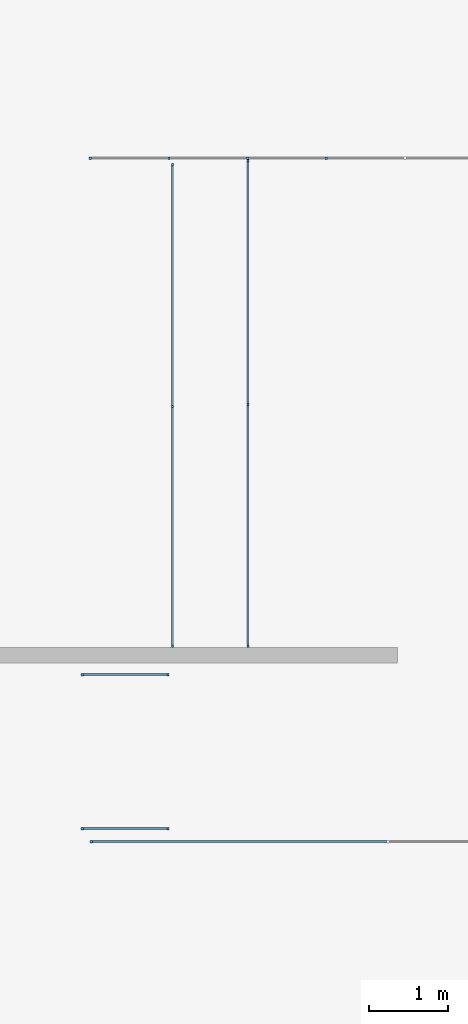
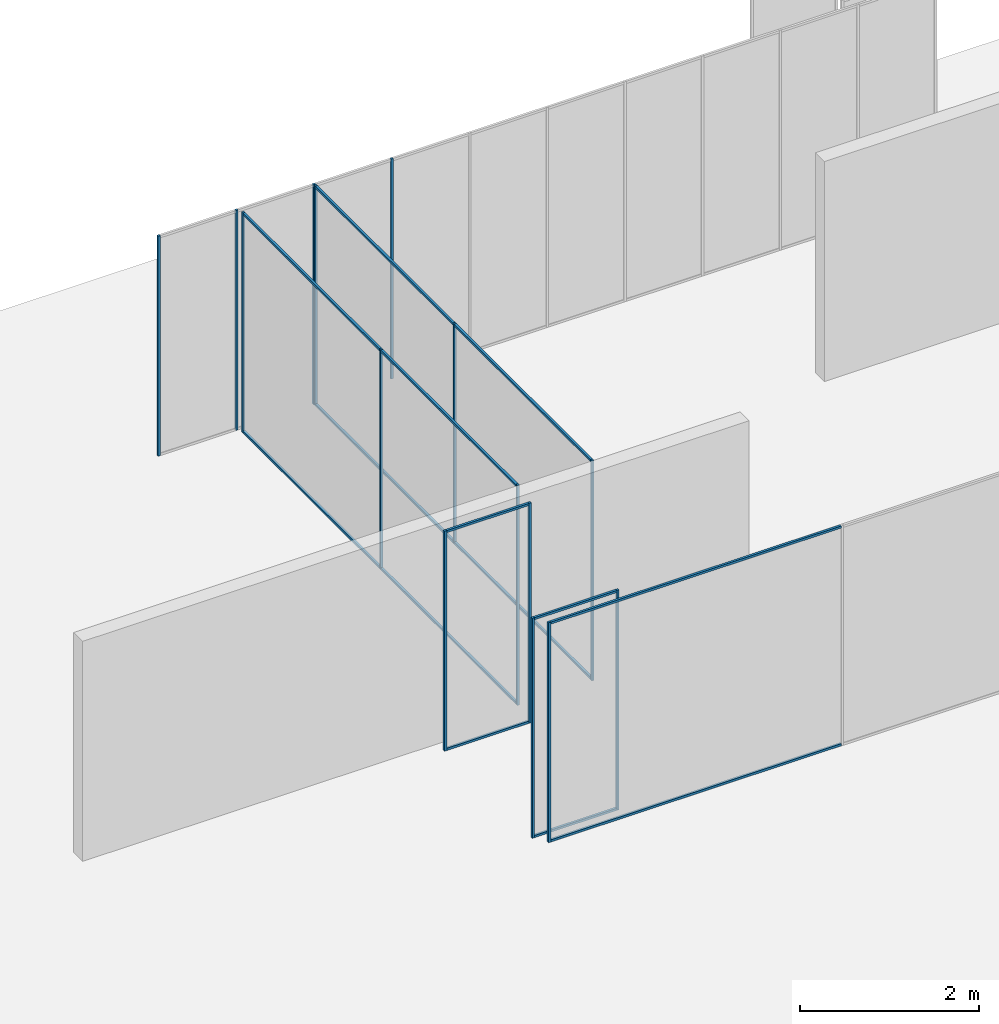
# One storey, part 1 of 8: 29 members, 6 elements without a shape of their own.
"""IFC2X3 building model written with IfcOpenShell, lengths in millimetres."""

import ifcopenshell
import ifcopenshell.guid

model = None  # the IFC model being written
_history = None  # IfcOwnerHistory: only IFC2X3 demands one
_inside = {}  # id of a spatial element -> (the spatial element, [elements in it])
_under = {}  # id of a project, library or spatial element -> (it, [spatial elements below it])
_declared = {}  # id of a project -> (the project, [libraries it declares])
_typed = {}  # id of a type object -> (the type object, [elements of that type])
_made_of = {}  # id of a material, layer set ... -> (it, [elements and type objects made of it])


def new_model(schema):
    """Start an empty IFC model of exactly this schema.

    Asked for "IFC4X3", IfcOpenShell would pick the latest addendum, in which some entities
    have other attributes; the version numbers below select the first issue.
    IFC2X3 requires an IfcOwnerHistory on every rooted entity: one is made here for all.
    """
    global model, _history
    if schema == "IFC4X3":
        model = ifcopenshell.file(schema_version=(4, 3, 0, 0))
    else:
        model = ifcopenshell.file(schema=schema)
    _inside.clear()
    _under.clear()
    _declared.clear()
    _typed.clear()
    _made_of.clear()
    _history = None
    if model.schema == "IFC2X3":
        org = make("IfcOrganization", Name="unknown")
        user = make(
            "IfcPersonAndOrganization",
            ThePerson=make("IfcPerson", FamilyName="unknown"),
            TheOrganization=org,
        )
        app = make(
            "IfcApplication",
            ApplicationDeveloper=org,
            Version="unknown",
            ApplicationFullName="unknown",
            ApplicationIdentifier="unknown",
        )
        _history = make(
            "IfcOwnerHistory",
            OwningUser=user,
            OwningApplication=app,
            ChangeAction="ADDED",
            CreationDate=0,
        )
    return model


def make(cls, **values):
    """One entity of the class cls with the attributes given. An attribute that is None is left unset."""
    return model.create_entity(
        cls, **{name: value for name, value in values.items() if value is not None}
    )


def entity(cls, *values):
    """Any entity or typed value of the class cls, its attributes in the order of the schema. None: left unset."""
    e = model.create_entity(cls)
    for i, value in enumerate(values):
        if value is not None:
            e[i] = value
    return e


def rooted(cls, **values):
    """An entity with a GlobalId (a new one), such as an element, a storey or a relation."""
    return make(cls, GlobalId=ifcopenshell.guid.new(), OwnerHistory=_history, **values)


def si_unit(unit_type, name, prefix=None):
    """IfcSIUnit, for example si_unit("LENGTHUNIT", "METRE", prefix="MILLI")."""
    return make("IfcSIUnit", UnitType=unit_type, Prefix=prefix, Name=name)


def converted_unit(unit_type, name, factor, base, dimensions=None, offset=None):
    """IfcConversionBasedUnit, such as the inch: factor (a typed value) times the base unit."""
    return make(
        "IfcConversionBasedUnit"
        if offset is None
        else "IfcConversionBasedUnitWithOffset",
        ConversionOffset=offset,
        Dimensions=None
        if dimensions is None
        else entity("IfcDimensionalExponents", *dimensions),
        UnitType=unit_type,
        Name=name,
        ConversionFactor=make(
            "IfcMeasureWithUnit", ValueComponent=factor, UnitComponent=base
        ),
    )


def assignment(units):
    """IfcUnitAssignment: the units of a project."""
    return None if units is None else make("IfcUnitAssignment", Units=units)


def point(xyz):
    """IfcCartesianPoint."""
    return None if xyz is None else make("IfcCartesianPoint", Coordinates=xyz)


def direction(xyz):
    """IfcDirection."""
    return None if xyz is None else make("IfcDirection", DirectionRatios=xyz)


def frame(location, z_axis=None, x_axis=None):
    """IfcAxis2Placement3D, a coordinate frame: its origin and axes. An axis left out is left unset."""
    return make(
        "IfcAxis2Placement3D",
        Location=point(location),
        Axis=direction(z_axis),
        RefDirection=direction(x_axis),
    )


def frame_2d(location, x_axis=None):
    """IfcAxis2Placement2D, a coordinate frame in the plane: its origin and x axis."""
    return make(
        "IfcAxis2Placement2D", Location=point(location), RefDirection=direction(x_axis)
    )


def origin():
    """The frame at (0, 0, 0) with its axes left unset."""
    return frame((0.0, 0.0, 0.0))


def origin_2d_with_axis():
    """The frame at (0, 0) in the plane with the x axis (1, 0) written out."""
    return frame_2d((0.0, 0.0), x_axis=(1.0, 0.0))


def place(relative_to, where):
    """IfcLocalPlacement: puts the frame where relative to a parent placement (None: the world)."""
    return make(
        "IfcLocalPlacement", PlacementRelTo=relative_to, RelativePlacement=where
    )


def context(
    kind, dimensions, precision=None, world=None, true_north=None, identifier=None
):
    """IfcGeometricRepresentationContext, for example the 3D "Model" context."""
    return make(
        "IfcGeometricRepresentationContext",
        ContextIdentifier=identifier,
        ContextType=kind,
        CoordinateSpaceDimension=dimensions,
        Precision=precision,
        WorldCoordinateSystem=world,
        TrueNorth=true_north,
    )


def subcontext(parent, identifier, kind, view, scale=None):
    """IfcGeometricRepresentationSubContext, for example "Body" below "Model"."""
    return make(
        "IfcGeometricRepresentationSubContext",
        ContextIdentifier=identifier,
        ContextType=kind,
        ParentContext=parent,
        TargetScale=scale,
        TargetView=view,
    )


def project(units=None, contexts=None):
    """IfcProject with its units and contexts."""
    return rooted(
        "IfcProject",
        Name="project",
        RepresentationContexts=contexts,
        UnitsInContext=assignment(units),
    )


def spatial(cls, under=None, at=None, **own):
    """A site, building, storey or space (cls), placed at a placement, below another one or the project."""
    s = rooted(cls, ObjectPlacement=at, **own)
    if under is not None:
        _under.setdefault(under.id(), (under, []))[1].append(s)
    return s


def profile(cls, at=None, kind="AREA", **sizes):
    """A parametric profile (cls). Its sizes go by their IFC names, for example OverallWidth=200.0."""
    return make(cls, ProfileType=kind, Position=at, **sizes)


def rectangle(**sizes):
    """IfcRectangleProfileDef."""
    return profile("IfcRectangleProfileDef", **sizes)


def extrude(swept, where, along, depth):
    """IfcExtrudedAreaSolid: the profile swept, set in the frame where, extruded along a direction by depth."""
    return make(
        "IfcExtrudedAreaSolid",
        SweptArea=swept,
        Position=where,
        ExtrudedDirection=direction(along),
        Depth=depth,
    )


def shape(context_of_items, identifier, shape_type, items):
    """IfcShapeRepresentation: the items that make up one representation, for example the "Body"."""
    return make(
        "IfcShapeRepresentation",
        ContextOfItems=context_of_items,
        RepresentationIdentifier=identifier,
        RepresentationType=shape_type,
        Items=items,
    )


def made_of(thing, what):
    """Note that an element or type object is made of a material, layer set ...; save() writes the relation."""
    if what is not None:
        _made_of.setdefault(what.id(), (what, []))[1].append(thing)
    return thing


def element(
    cls,
    number,
    at=None,
    inside=None,
    cuts=None,
    type_object=None,
    material=None,
    context=None,
    identifier="Body",
    shape_type=None,
    held_by="IfcProductDefinitionShape",
    body=None,
    shapes=None,
    **own,
):
    """One element of the class cls, such as IfcWall. Its Tag is "e" and its number.

    at: its placement. inside: the storey or other place that contains it. cuts: it is an
    opening in that element (IfcRelVoidsElement). A single representation is given by context,
    identifier, shape_type and body (its items); several are given by shapes. held_by: the class
    of the entity that holds the representations. save() writes the other relations.
    """
    e = rooted(cls, Tag="e%d" % number, ObjectPlacement=at, **own)
    if body is not None:
        shapes = [shape(context, identifier, shape_type, body)]
    if shapes is not None:
        e.Representation = make(held_by, Representations=shapes)
    if inside is not None:
        _inside.setdefault(inside.id(), (inside, []))[1].append(e)
    if cuts is not None:
        rooted(
            "IfcRelVoidsElement", RelatingBuildingElement=cuts, RelatedOpeningElement=e
        )
    if type_object is not None:
        _typed.setdefault(type_object.id(), (type_object, []))[1].append(e)
    return made_of(e, material)


def aggregate(whole, parts):
    """IfcRelAggregates: a whole, such as a stair, and the parts it consists of."""
    return rooted("IfcRelAggregates", RelatingObject=whole, RelatedObjects=parts)


def save(model, path):
    """Write the relations noted so far, then the file.

    IfcRelAggregates (storeys below a building ...), IfcRelContainedInSpatialStructure (elements
    in a storey), IfcRelDefinesByType, IfcRelAssociatesMaterial and IfcRelDeclares: one each for
    every whole, place, type object, material and project.
    """
    for whole, parts in _under.values():
        aggregate(whole, parts)
    for where, things in _inside.values():
        rooted(
            "IfcRelContainedInSpatialStructure",
            RelatedElements=things,
            RelatingStructure=where,
        )
    for kind, things in _typed.values():
        rooted("IfcRelDefinesByType", RelatedObjects=things, RelatingType=kind)
    for what, things in _made_of.values():
        rooted("IfcRelAssociatesMaterial", RelatedObjects=things, RelatingMaterial=what)
    for by, libraries in _declared.values():
        rooted("IfcRelDeclares", RelatingContext=by, RelatedDefinitions=libraries)
    model.write(path)


model = new_model("IFC2X3")

# Units and contexts
model_context = context("Model", 3, precision=1e-06, world=origin(), true_north=direction((2.0, 6.12303176911189e-17, 1.0)))
context_of_model = context(None, 3, precision=1e-06, world=origin(), true_north=direction((2.0, 6.12303176911189e-17, 1.0)))
body_context = subcontext(model_context, "Body", "Model", "MODEL_VIEW")
ifc_project = project(units=[si_unit("LENGTHUNIT", "METRE", prefix="MILLI"), si_unit("AREAUNIT", "SQUARE_METRE", prefix="MILLI"), si_unit("VOLUMEUNIT", "CUBIC_METRE", prefix="MILLI"), converted_unit("PLANEANGLEUNIT", "DEGREE", entity("IfcRatioMeasure", 0.0174532925199433), si_unit("PLANEANGLEUNIT", "RADIAN"), dimensions=[0, 0, 0, 0, 0, 0, 0]), si_unit("TIMEUNIT", "SECOND")], contexts=[model_context, context_of_model])

# Site, building, storey
site_placement = place(None, origin())
site = spatial("IfcSite", under=ifc_project, at=site_placement, CompositionType="ELEMENT")
building_placement = place(site_placement, origin())
building = spatial("IfcBuilding", under=site, at=building_placement, CompositionType="ELEMENT")
storey_placement = place(building_placement, frame((0.0, 0.0, 1500.0)))
storey = spatial("IfcBuildingStorey", under=building, at=storey_placement, Name="Level 1", CompositionType="ELEMENT", Elevation=1500.0)

# Curtain wall, members
curtain_wall_1_placement = place(storey_placement, origin())
curtain_wall_1 = element("IfcCurtainWall", 1, at=curtain_wall_1_placement, inside=storey, Name="Curtain Wall:Curtain Wall", ObjectType="Curtain Wall:Curtain Wall:334")
member_1_placement = place(storey_placement, origin())
member_1 = element("IfcMember", 2, at=member_1_placement, Name="Curtain Wall:Curtain Wall:8490", ObjectType="Curtain Wall:Curtain Wall:8490", context=body_context, shape_type="SweptSolid", body=[
    extrude(rectangle(XDim=30.0000000000002, YDim=30.0000000000008, at=frame_2d((2.70894418008538e-13, 5.41788836017076e-13), x_axis=(1.0, 0.0))), frame((4994.0, 2575.0, 0.0), z_axis=(0.0, 0.0, 1.0), x_axis=(0.0, -1.0, 0.0)), (0.0, 0.0, 1.0), 3000.0),
])
member_2_placement = place(storey_placement, origin())
member_2 = element("IfcMember", 3, at=member_2_placement, Name="Curtain Wall:Curtain Wall:8490", ObjectType="Curtain Wall:Curtain Wall:8490", context=body_context, shape_type="SweptSolid", body=[
    extrude(rectangle(XDim=30.0000000000002, YDim=30.0000000000008, at=frame_2d((2.70894418008538e-13, 5.41788836017076e-13), x_axis=(1.0, 0.0))), frame((5995.5, 2575.0, 0.0), z_axis=(0.0, 0.0, 1.0), x_axis=(0.0, -1.0, 0.0)), (0.0, 0.0, 1.0), 3000.0),
])
member_3_placement = place(storey_placement, origin())
member_3 = element("IfcMember", 4, at=member_3_placement, Name="Curtain Wall:Curtain Wall:8490", ObjectType="Curtain Wall:Curtain Wall:8490", context=body_context, shape_type="SweptSolid", body=[
    extrude(rectangle(XDim=30.0000000000002, YDim=30.0000000000008, at=frame_2d((2.70894418008538e-13, -5.41788836017076e-13), x_axis=(1.0, 0.0))), frame((6997.0, 2575.0, 0.0), z_axis=(0.0, 0.0, 1.0), x_axis=(0.0, -1.0, 0.0)), (0.0, 0.0, 1.0), 3000.0),
])
member_4_placement = place(storey_placement, origin())
member_4 = element("IfcMember", 5, at=member_4_placement, Name="Curtain Wall:Curtain Wall:8490", ObjectType="Curtain Wall:Curtain Wall:8490", context=body_context, shape_type="SweptSolid", body=[
    extrude(rectangle(XDim=30.0000000000002, YDim=30.0000000000002, at=frame_2d((2.70894418008538e-13, 0.0), x_axis=(1.0, 0.0))), frame((3992.5, 2575.0, 0.0), z_axis=(0.0, 0.0, 1.0), x_axis=(0.0, -1.0, 0.0)), (0.0, 0.0, 1.0), 3000.0),
])
aggregate(curtain_wall_1, [member_1, member_2, member_3, member_4])

curtain_wall_2_placement = place(storey_placement, origin())
curtain_wall_2 = element("IfcCurtainWall", 6, at=curtain_wall_2_placement, inside=storey, Name="Curtain Wall:Curtain Wall", ObjectType="Curtain Wall:Curtain Wall:334")
member_5_placement = place(storey_placement, origin())
member_5 = element("IfcMember", 7, at=member_5_placement, Name="Curtain Wall:Curtain Wall:8490", ObjectType="Curtain Wall:Curtain Wall:8490", context=body_context, shape_type="SweptSolid", body=[
    extrude(rectangle(XDim=3075.00000000002, YDim=29.9999999999997, at=origin_2d_with_axis()), frame((5999.85915853028, 992.500000000011, 2970.0), z_axis=(0.0, 0.0, 1.0), x_axis=(0.0, 1.0, 0.0)), (0.0, 0.0, 1.0), 30.0000000000002),
])
member_6_placement = place(storey_placement, origin())
member_6 = element("IfcMember", 8, at=member_6_placement, Name="Curtain Wall:Curtain Wall:8490", ObjectType="Curtain Wall:Curtain Wall:8490", context=body_context, shape_type="SweptSolid", body=[
    extrude(rectangle(XDim=3045.00000000002, YDim=29.9999999999997, at=frame_2d((-1.13686837721616e-13, 0.0), x_axis=(1.0, 0.0))), frame((5999.85915853027, -2097.50000000001, 0.0), z_axis=(0.0, 0.0, 1.0), x_axis=(0.0, -1.0, 0.0)), (0.0, 0.0, 1.0), 29.9999999999999),
])
member_7_placement = place(storey_placement, origin())
member_7 = element("IfcMember", 9, at=member_7_placement, Name="Curtain Wall:Curtain Wall:8490", ObjectType="Curtain Wall:Curtain Wall:8490", context=body_context, shape_type="SweptSolid", body=[
    extrude(rectangle(XDim=30.0000000000008, YDim=29.9999999999997, at=frame_2d((5.41788836017076e-13, 0.0), x_axis=(1.0, 0.0))), frame((5999.85915853027, -3635.0, 0.0)), (0.0, 0.0, 1.0), 3000.0),
])
member_8_placement = place(storey_placement, origin())
member_8 = element("IfcMember", 10, at=member_8_placement, Name="Curtain Wall:Curtain Wall:8490", ObjectType="Curtain Wall:Curtain Wall:8490", context=body_context, shape_type="SweptSolid", body=[
    extrude(rectangle(XDim=3075.00000000002, YDim=29.9999999999997, at=origin_2d_with_axis()), frame((5999.85915853028, 992.500000000011, 0.0), z_axis=(0.0, 0.0, 1.0), x_axis=(0.0, -1.0, 0.0)), (0.0, 0.0, 1.0), 29.9999999999999),
])
member_9_placement = place(storey_placement, origin())
member_9 = element("IfcMember", 11, at=member_9_placement, Name="Curtain Wall:Curtain Wall:8490", ObjectType="Curtain Wall:Curtain Wall:8490", context=body_context, shape_type="SweptSolid", body=[
    extrude(rectangle(XDim=3045.00000000002, YDim=29.9999999999997, at=origin_2d_with_axis()), frame((5999.85915853027, -2097.50000000001, 2970.0), z_axis=(0.0, 0.0, 1.0), x_axis=(0.0, 1.0, 0.0)), (0.0, 0.0, 1.0), 30.0000000000002),
])
member_10_placement = place(storey_placement, origin())
member_10 = element("IfcMember", 12, at=member_10_placement, Name="Curtain Wall:Curtain Wall:8490", ObjectType="Curtain Wall:Curtain Wall:8490", context=body_context, shape_type="SweptSolid", body=[
    extrude(rectangle(XDim=29.9999999999997, YDim=30.0, at=origin_2d_with_axis()), frame((5999.85915853028, -560.0, 0.0)), (0.0, 0.0, 1.0), 3000.0),
])
member_11_placement = place(storey_placement, origin())
member_11 = element("IfcMember", 13, at=member_11_placement, Name="Curtain Wall:Curtain Wall:8490", ObjectType="Curtain Wall:Curtain Wall:8490", context=body_context, shape_type="SweptSolid", body=[
    extrude(rectangle(XDim=29.9999999999997, YDim=29.9999999999997, at=frame_2d((2.70894418008538e-13, 0.0), x_axis=(1.0, 0.0))), frame((5999.85915853028, 2545.0, 0.0), z_axis=(0.0, 0.0, 1.0), x_axis=(0.0, -1.0, 0.0)), (0.0, 0.0, 1.0), 3000.0),
])
aggregate(curtain_wall_2, [member_5, member_6, member_7, member_8, member_9, member_10, member_11])

curtain_wall_3_placement = place(storey_placement, origin())
curtain_wall_3 = element("IfcCurtainWall", 14, at=curtain_wall_3_placement, inside=storey, Name="Curtain Wall:Curtain Wall", ObjectType="Curtain Wall:Curtain Wall:334")
member_12_placement = place(storey_placement, origin())
member_12 = element("IfcMember", 15, at=member_12_placement, Name="Curtain Wall:Curtain Wall:8490", ObjectType="Curtain Wall:Curtain Wall:8490", context=body_context, shape_type="SweptSolid", body=[
    extrude(rectangle(XDim=3050.0, YDim=29.9999999999997, at=frame_2d((1.13686837721616e-13, 0.0), x_axis=(1.0, 0.0))), frame((5037.5, 955.0, 2970.0), z_axis=(0.0, 0.0, 1.0), x_axis=(0.0, 1.0, 0.0)), (0.0, 0.0, 1.0), 30.0000000000002),
])
member_13_placement = place(storey_placement, origin())
member_13 = element("IfcMember", 16, at=member_13_placement, Name="Curtain Wall:Curtain Wall:8490", ObjectType="Curtain Wall:Curtain Wall:8490", context=body_context, shape_type="SweptSolid", body=[
    extrude(rectangle(XDim=3020.0, YDim=29.9999999999997, at=origin_2d_with_axis()), frame((5037.49999999999, -2110.0, 0.0), z_axis=(0.0, 0.0, 1.0), x_axis=(0.0, -1.0, 0.0)), (0.0, 0.0, 1.0), 29.9999999999999),
])
member_14_placement = place(storey_placement, origin())
member_14 = element("IfcMember", 17, at=member_14_placement, Name="Curtain Wall:Curtain Wall:8490", ObjectType="Curtain Wall:Curtain Wall:8490", context=body_context, shape_type="SweptSolid", body=[
    extrude(rectangle(XDim=30.0000000000008, YDim=29.9999999999997, at=frame_2d((5.41788836017076e-13, 0.0), x_axis=(1.0, 0.0))), frame((5037.49999999999, -3635.0, 0.0)), (0.0, 0.0, 1.0), 3000.0),
])
member_15_placement = place(storey_placement, origin())
member_15 = element("IfcMember", 18, at=member_15_placement, Name="Curtain Wall:Curtain Wall:8490", ObjectType="Curtain Wall:Curtain Wall:8490", context=body_context, shape_type="SweptSolid", body=[
    extrude(rectangle(XDim=3050.0, YDim=29.9999999999997, at=origin_2d_with_axis()), frame((5037.5, 955.0, 0.0), z_axis=(0.0, 0.0, 1.0), x_axis=(0.0, -1.0, 0.0)), (0.0, 0.0, 1.0), 29.9999999999999),
])
member_16_placement = place(storey_placement, origin())
member_16 = element("IfcMember", 19, at=member_16_placement, Name="Curtain Wall:Curtain Wall:8490", ObjectType="Curtain Wall:Curtain Wall:8490", context=body_context, shape_type="SweptSolid", body=[
    extrude(rectangle(XDim=3020.0, YDim=29.9999999999997, at=origin_2d_with_axis()), frame((5037.49999999999, -2110.0, 2970.0), z_axis=(0.0, 0.0, 1.0), x_axis=(0.0, 1.0, 0.0)), (0.0, 0.0, 1.0), 30.0000000000002),
])
member_17_placement = place(storey_placement, origin())
member_17 = element("IfcMember", 20, at=member_17_placement, Name="Curtain Wall:Curtain Wall:8490", ObjectType="Curtain Wall:Curtain Wall:8490", context=body_context, shape_type="SweptSolid", body=[
    extrude(rectangle(XDim=29.9999999999997, YDim=30.0, at=origin_2d_with_axis()), frame((5037.5, -585.0, 0.0)), (0.0, 0.0, 1.0), 3000.0),
])
member_18_placement = place(storey_placement, origin())
member_18 = element("IfcMember", 21, at=member_18_placement, Name="Curtain Wall:Curtain Wall:8490", ObjectType="Curtain Wall:Curtain Wall:8490", context=body_context, shape_type="SweptSolid", body=[
    extrude(rectangle(XDim=29.9999999999997, YDim=29.9999999999997, at=frame_2d((2.70894418008538e-13, 0.0), x_axis=(1.0, 0.0))), frame((5037.5, 2495.0, 0.0), z_axis=(0.0, 0.0, 1.0), x_axis=(0.0, -1.0, 0.0)), (0.0, 0.0, 1.0), 3000.0),
])
aggregate(curtain_wall_3, [member_12, member_13, member_14, member_15, member_16, member_17, member_18])

curtain_wall_4_placement = place(storey_placement, origin())
curtain_wall_4 = element("IfcCurtainWall", 22, at=curtain_wall_4_placement, inside=storey, Name="Curtain Wall:Curtain Wall", ObjectType="Curtain Wall:Curtain Wall:334")
member_19_placement = place(storey_placement, origin())
member_19 = element("IfcMember", 23, at=member_19_placement, Name="Curtain Wall:Curtain Wall:8490", ObjectType="Curtain Wall:Curtain Wall:8490", context=body_context, shape_type="SweptSolid", body=[
    extrude(rectangle(XDim=3746.66666666667, YDim=29.9999999999997, at=frame_2d((4.54747350886464e-13, -5.41788836017076e-13), x_axis=(1.0, 0.0))), frame((5893.33333333333, -6125.0, 0.0), z_axis=(0.0, 0.0, 1.0), x_axis=(-1.0, 0.0, 0.0)), (0.0, 0.0, 1.0), 29.9999999999999),
])
member_20_placement = place(storey_placement, origin())
member_20 = element("IfcMember", 24, at=member_20_placement, Name="Curtain Wall:Curtain Wall:8490", ObjectType="Curtain Wall:Curtain Wall:8490", context=body_context, shape_type="SweptSolid", body=[
    extrude(rectangle(XDim=30.0000000000008, YDim=30.0000000000002, at=frame_2d((5.41788836017076e-13, 0.0), x_axis=(1.0, 0.0))), frame((4005.0, -6125.0, 0.0), z_axis=(0.0, 0.0, 1.0), x_axis=(0.0, -1.0, 0.0)), (0.0, 0.0, 1.0), 3000.0),
])
member_21_placement = place(storey_placement, origin())
member_21 = element("IfcMember", 25, at=member_21_placement, Name="Curtain Wall:Curtain Wall:8490", ObjectType="Curtain Wall:Curtain Wall:8490", context=body_context, shape_type="SweptSolid", body=[
    extrude(rectangle(XDim=3746.66666666667, YDim=29.9999999999997, at=frame_2d((5.6843418860808e-13, 5.41788836017076e-13), x_axis=(1.0, 0.0))), frame((5893.33333333333, -6125.0, 2970.0)), (0.0, 0.0, 1.0), 30.0000000000002),
])
aggregate(curtain_wall_4, [member_19, member_20, member_21])

curtain_wall_5_placement = place(storey_placement, origin())
curtain_wall_5 = element("IfcCurtainWall", 26, at=curtain_wall_5_placement, inside=storey, Name="Curtain Wall:Curtain Wall Zero Grid lines", ObjectType="Curtain Wall:Curtain Wall Zero Grid lines")
member_22_placement = place(storey_placement, origin())
member_22 = element("IfcMember", 27, at=member_22_placement, Name="Curtain Wall:Curtain Wall Zero Grid lines:8490", ObjectType="Curtain Wall:Curtain Wall Zero Grid lines:8490", context=body_context, shape_type="SweptSolid", body=[
    extrude(rectangle(XDim=1060.0, YDim=30.0000000000002, at=frame_2d((-2.8421709430404e-13, -2.70894418008538e-13), x_axis=(1.0, 0.0))), frame((4435.0, -4000.0, 0.0)), (0.0, 0.0, 1.0), 29.9999999999999),
])
member_23_placement = place(storey_placement, origin())
member_23 = element("IfcMember", 28, at=member_23_placement, Name="Curtain Wall:Curtain Wall Zero Grid lines:8490", ObjectType="Curtain Wall:Curtain Wall Zero Grid lines:8490", context=body_context, shape_type="SweptSolid", body=[
    extrude(rectangle(XDim=30.0000000000002, YDim=29.9999999999997, at=frame_2d((-2.70894418008538e-13, 0.0), x_axis=(1.0, 0.0))), frame((4980.0, -4000.0, 0.0), z_axis=(0.0, 0.0, 1.0), x_axis=(0.0, 1.0, 0.0)), (0.0, 0.0, 1.0), 3000.0),
])
member_24_placement = place(storey_placement, origin())
member_24 = element("IfcMember", 29, at=member_24_placement, Name="Curtain Wall:Curtain Wall Zero Grid lines:8490", ObjectType="Curtain Wall:Curtain Wall Zero Grid lines:8490", context=body_context, shape_type="SweptSolid", body=[
    extrude(rectangle(XDim=29.9999999999997, YDim=30.0000000000002, at=frame_2d((0.0, -2.70894418008538e-13), x_axis=(1.0, 0.0))), frame((3890.0, -4000.0, 0.0)), (0.0, 0.0, 1.0), 3000.0),
])
member_25_placement = place(storey_placement, origin())
member_25 = element("IfcMember", 30, at=member_25_placement, Name="Curtain Wall:Curtain Wall Zero Grid lines:8490", ObjectType="Curtain Wall:Curtain Wall Zero Grid lines:8490", context=body_context, shape_type="SweptSolid", body=[
    extrude(rectangle(XDim=1060.0, YDim=30.0000000000002, at=frame_2d((2.8421709430404e-13, 5.40900657597376e-13), x_axis=(1.0, 0.0))), frame((4435.0, -4000.0, 2970.0), z_axis=(0.0, 0.0, 1.0), x_axis=(-1.0, 0.0, 0.0)), (0.0, 0.0, 1.0), 30.0000000000002),
])
aggregate(curtain_wall_5, [member_22, member_23, member_24, member_25])

curtain_wall_6_placement = place(storey_placement, origin())
curtain_wall_6 = element("IfcCurtainWall", 31, at=curtain_wall_6_placement, inside=storey, Name="Curtain Wall:Curtain Wall Zero Grid lines", ObjectType="Curtain Wall:Curtain Wall Zero Grid lines")
member_26_placement = place(storey_placement, origin())
member_26 = element("IfcMember", 32, at=member_26_placement, Name="Curtain Wall:Curtain Wall Zero Grid lines:8490", ObjectType="Curtain Wall:Curtain Wall Zero Grid lines:8490", context=body_context, shape_type="SweptSolid", body=[
    extrude(rectangle(XDim=1060.0, YDim=29.9999999999997, at=frame_2d((-2.8421709430404e-13, -5.41788836017076e-13), x_axis=(1.0, 0.0))), frame((4435.0, -5960.0, 0.0)), (0.0, 0.0, 1.0), 29.9999999999999),
])
member_27_placement = place(storey_placement, origin())
member_27 = element("IfcMember", 33, at=member_27_placement, Name="Curtain Wall:Curtain Wall Zero Grid lines:8490", ObjectType="Curtain Wall:Curtain Wall Zero Grid lines:8490", context=body_context, shape_type="SweptSolid", body=[
    extrude(rectangle(XDim=30.0000000000008, YDim=29.9999999999997, at=frame_2d((5.41788836017076e-13, 1.08357767203415e-12), x_axis=(1.0, 0.0))), frame((4980.0, -5960.0, 0.0), z_axis=(0.0, 0.0, 1.0), x_axis=(0.0, 1.0, 0.0)), (0.0, 0.0, 1.0), 3000.0),
])
member_28_placement = place(storey_placement, origin())
member_28 = element("IfcMember", 34, at=member_28_placement, Name="Curtain Wall:Curtain Wall Zero Grid lines:8490", ObjectType="Curtain Wall:Curtain Wall Zero Grid lines:8490", context=body_context, shape_type="SweptSolid", body=[
    extrude(rectangle(XDim=29.9999999999997, YDim=29.9999999999997, at=origin_2d_with_axis()), frame((3890.0, -5960.0, 0.0)), (0.0, 0.0, 1.0), 3000.0),
])
member_29_placement = place(storey_placement, origin())
member_29 = element("IfcMember", 35, at=member_29_placement, Name="Curtain Wall:Curtain Wall Zero Grid lines:8490", ObjectType="Curtain Wall:Curtain Wall Zero Grid lines:8490", context=body_context, shape_type="SweptSolid", body=[
    extrude(rectangle(XDim=1060.0, YDim=29.9999999999997, at=frame_2d((2.8421709430404e-13, 5.41788836017076e-13), x_axis=(1.0, 0.0))), frame((4435.0, -5960.0, 2970.0), z_axis=(0.0, 0.0, 1.0), x_axis=(-1.0, 0.0, 0.0)), (0.0, 0.0, 1.0), 30.0000000000002),
])
aggregate(curtain_wall_6, [member_26, member_27, member_28, member_29])

save(model, "model.ifc")
